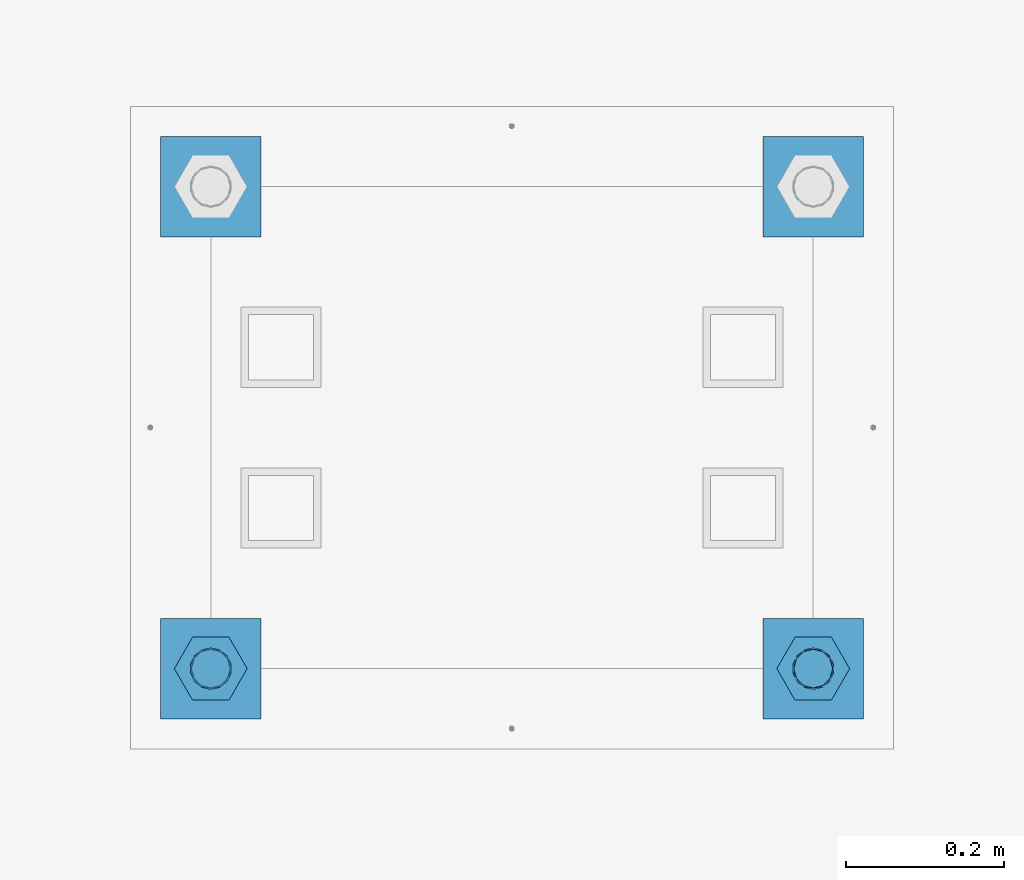
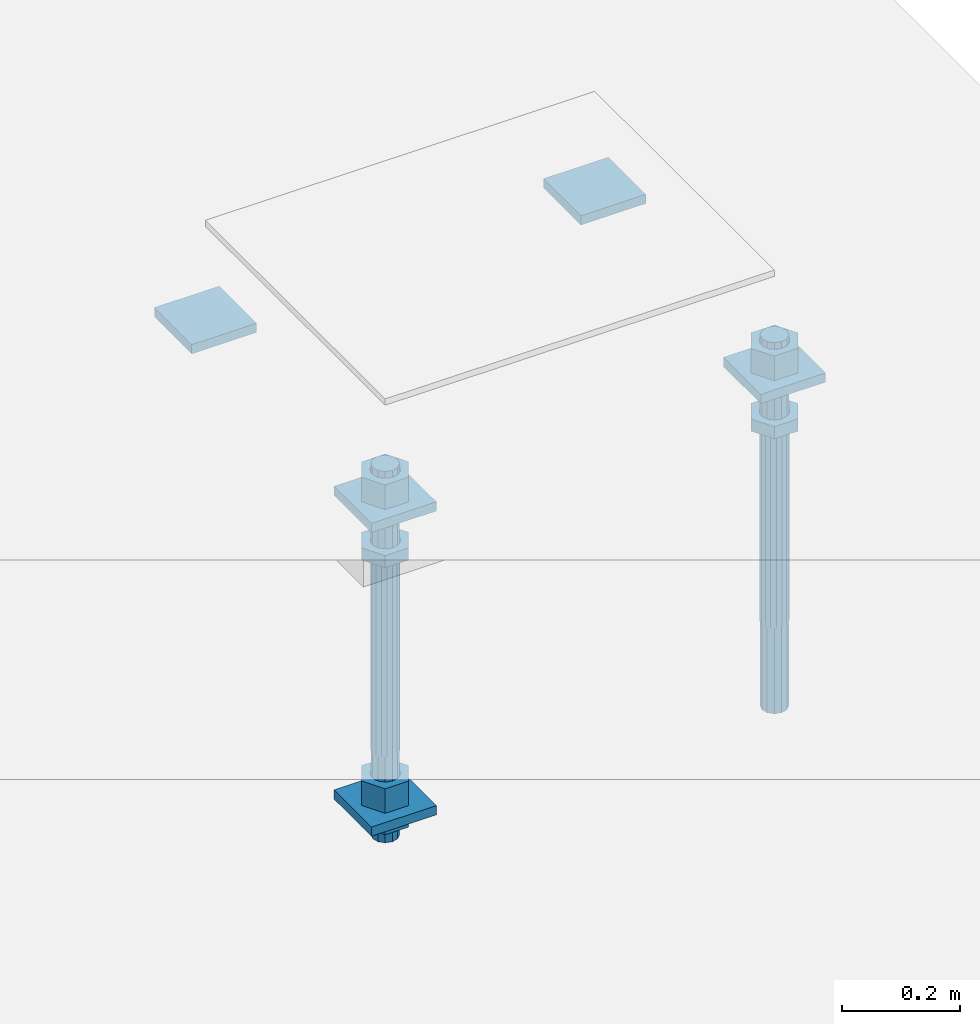
# One storey, part 2678 of 3843: 13 beams, 1 element without a shape of its own.
"""IFC2X3 building model written with IfcOpenShell, lengths in millimetres."""

import ifcopenshell
import ifcopenshell.guid

model = None  # the IFC model being written
_history = None  # IfcOwnerHistory: only IFC2X3 demands one
_inside = {}  # id of a spatial element -> (the spatial element, [elements in it])
_under = {}  # id of a project, library or spatial element -> (it, [spatial elements below it])
_declared = {}  # id of a project -> (the project, [libraries it declares])
_typed = {}  # id of a type object -> (the type object, [elements of that type])
_made_of = {}  # id of a material, layer set ... -> (it, [elements and type objects made of it])


def new_model(schema):
    """Start an empty IFC model of exactly this schema.

    Asked for "IFC4X3", IfcOpenShell would pick the latest addendum, in which some entities
    have other attributes; the version numbers below select the first issue.
    IFC2X3 requires an IfcOwnerHistory on every rooted entity: one is made here for all.
    """
    global model, _history
    if schema == "IFC4X3":
        model = ifcopenshell.file(schema_version=(4, 3, 0, 0))
    else:
        model = ifcopenshell.file(schema=schema)
    _inside.clear()
    _under.clear()
    _declared.clear()
    _typed.clear()
    _made_of.clear()
    _history = None
    if model.schema == "IFC2X3":
        org = make("IfcOrganization", Name="unknown")
        user = make(
            "IfcPersonAndOrganization",
            ThePerson=make("IfcPerson", FamilyName="unknown"),
            TheOrganization=org,
        )
        app = make(
            "IfcApplication",
            ApplicationDeveloper=org,
            Version="unknown",
            ApplicationFullName="unknown",
            ApplicationIdentifier="unknown",
        )
        _history = make(
            "IfcOwnerHistory",
            OwningUser=user,
            OwningApplication=app,
            ChangeAction="ADDED",
            CreationDate=0,
        )
    return model


def make(cls, **values):
    """One entity of the class cls with the attributes given. An attribute that is None is left unset."""
    return model.create_entity(
        cls, **{name: value for name, value in values.items() if value is not None}
    )


def rooted(cls, **values):
    """An entity with a GlobalId (a new one), such as an element, a storey or a relation."""
    return make(cls, GlobalId=ifcopenshell.guid.new(), OwnerHistory=_history, **values)


def si_unit(unit_type, name, prefix=None):
    """IfcSIUnit, for example si_unit("LENGTHUNIT", "METRE", prefix="MILLI")."""
    return make("IfcSIUnit", UnitType=unit_type, Prefix=prefix, Name=name)


def assignment(units):
    """IfcUnitAssignment: the units of a project."""
    return None if units is None else make("IfcUnitAssignment", Units=units)


def point(xyz):
    """IfcCartesianPoint."""
    return None if xyz is None else make("IfcCartesianPoint", Coordinates=xyz)


def direction(xyz):
    """IfcDirection."""
    return None if xyz is None else make("IfcDirection", DirectionRatios=xyz)


def frame(location, z_axis=None, x_axis=None):
    """IfcAxis2Placement3D, a coordinate frame: its origin and axes. An axis left out is left unset."""
    return make(
        "IfcAxis2Placement3D",
        Location=point(location),
        Axis=direction(z_axis),
        RefDirection=direction(x_axis),
    )


def origin_with_axes():
    """The frame at (0, 0, 0) with the z axis (0, 0, 1) and the x axis (1, 0, 0) written out."""
    return frame((0.0, 0.0, 0.0), z_axis=(0.0, 0.0, 1.0), x_axis=(1.0, 0.0, 0.0))


def place(relative_to, where):
    """IfcLocalPlacement: puts the frame where relative to a parent placement (None: the world)."""
    return make(
        "IfcLocalPlacement", PlacementRelTo=relative_to, RelativePlacement=where
    )


def context(
    kind, dimensions, precision=None, world=None, true_north=None, identifier=None
):
    """IfcGeometricRepresentationContext, for example the 3D "Model" context."""
    return make(
        "IfcGeometricRepresentationContext",
        ContextIdentifier=identifier,
        ContextType=kind,
        CoordinateSpaceDimension=dimensions,
        Precision=precision,
        WorldCoordinateSystem=world,
        TrueNorth=true_north,
    )


def subcontext(parent, identifier, kind, view, scale=None):
    """IfcGeometricRepresentationSubContext, for example "Body" below "Model"."""
    return make(
        "IfcGeometricRepresentationSubContext",
        ContextIdentifier=identifier,
        ContextType=kind,
        ParentContext=parent,
        TargetScale=scale,
        TargetView=view,
    )


def project(units=None, contexts=None):
    """IfcProject with its units and contexts."""
    return rooted(
        "IfcProject",
        Name="project",
        RepresentationContexts=contexts,
        UnitsInContext=assignment(units),
    )


def spatial(cls, under=None, at=None, **own):
    """A site, building, storey or space (cls), placed at a placement, below another one or the project."""
    s = rooted(cls, ObjectPlacement=at, **own)
    if under is not None:
        _under.setdefault(under.id(), (under, []))[1].append(s)
    return s


def faces_of(points, faces, orient=None, outer=None):
    """IfcFace entities. A face is a list of loops; a loop is a list of indices into points, from 0.

    orient and outer hold one flag for each loop. By default every Orientation is true, the
    first loop of a face is its IfcFaceOuterBound and the others are IfcFaceBound.
    """
    made = []
    for i, loops in enumerate(faces):
        bounds = []
        for j, loop in enumerate(loops):
            is_outer = j == 0 if outer is None else outer[i][j]
            bounds.append(
                make(
                    "IfcFaceOuterBound" if is_outer else "IfcFaceBound",
                    Bound=make("IfcPolyLoop", Polygon=[points[k] for k in loop]),
                    Orientation=True if orient is None else orient[i][j],
                )
            )
        made.append(make("IfcFace", Bounds=bounds))
    return made


def faceted_brep(points, faces, orient=None, outer=None, voids=None):
    """IfcFacetedBrep: a solid bounded by flat faces; with voids (closed shells), ...WithVoids."""
    shared = [point(p) for p in points]
    hull = make("IfcClosedShell", CfsFaces=faces_of(shared, faces, orient, outer))
    if voids is None:
        return make("IfcFacetedBrep", Outer=hull)
    return make(
        "IfcFacetedBrepWithVoids",
        Outer=hull,
        Voids=[
            make(cls, CfsFaces=faces_of(shared, fs, o, b)) for cls, fs, o, b in voids
        ],
    )


def shape(context_of_items, identifier, shape_type, items):
    """IfcShapeRepresentation: the items that make up one representation, for example the "Body"."""
    return make(
        "IfcShapeRepresentation",
        ContextOfItems=context_of_items,
        RepresentationIdentifier=identifier,
        RepresentationType=shape_type,
        Items=items,
    )


def material(Name=None, Category=None):
    """IfcMaterial."""
    return make("IfcMaterial", Name=Name, Category=Category)


def made_of(thing, what):
    """Note that an element or type object is made of a material, layer set ...; save() writes the relation."""
    if what is not None:
        _made_of.setdefault(what.id(), (what, []))[1].append(thing)
    return thing


def type_object(cls, material=None, **own):
    """A type object (cls), such as IfcWallType, which elements share."""
    return made_of(rooted(cls, **own), material)


def element(
    cls,
    number,
    at=None,
    inside=None,
    cuts=None,
    type_object=None,
    material=None,
    context=None,
    identifier="Body",
    shape_type=None,
    held_by="IfcProductDefinitionShape",
    body=None,
    shapes=None,
    **own,
):
    """One element of the class cls, such as IfcWall. Its Tag is "e" and its number.

    at: its placement. inside: the storey or other place that contains it. cuts: it is an
    opening in that element (IfcRelVoidsElement). A single representation is given by context,
    identifier, shape_type and body (its items); several are given by shapes. held_by: the class
    of the entity that holds the representations. save() writes the other relations.
    """
    e = rooted(cls, Tag="e%d" % number, ObjectPlacement=at, **own)
    if body is not None:
        shapes = [shape(context, identifier, shape_type, body)]
    if shapes is not None:
        e.Representation = make(held_by, Representations=shapes)
    if inside is not None:
        _inside.setdefault(inside.id(), (inside, []))[1].append(e)
    if cuts is not None:
        rooted(
            "IfcRelVoidsElement", RelatingBuildingElement=cuts, RelatedOpeningElement=e
        )
    if type_object is not None:
        _typed.setdefault(type_object.id(), (type_object, []))[1].append(e)
    return made_of(e, material)


def aggregate(whole, parts):
    """IfcRelAggregates: a whole, such as a stair, and the parts it consists of."""
    return rooted("IfcRelAggregates", RelatingObject=whole, RelatedObjects=parts)


def save(model, path):
    """Write the relations noted so far, then the file.

    IfcRelAggregates (storeys below a building ...), IfcRelContainedInSpatialStructure (elements
    in a storey), IfcRelDefinesByType, IfcRelAssociatesMaterial and IfcRelDeclares: one each for
    every whole, place, type object, material and project.
    """
    for whole, parts in _under.values():
        aggregate(whole, parts)
    for where, things in _inside.values():
        rooted(
            "IfcRelContainedInSpatialStructure",
            RelatedElements=things,
            RelatingStructure=where,
        )
    for kind, things in _typed.values():
        rooted("IfcRelDefinesByType", RelatedObjects=things, RelatingType=kind)
    for what, things in _made_of.values():
        rooted("IfcRelAssociatesMaterial", RelatedObjects=things, RelatingMaterial=what)
    for by, libraries in _declared.values():
        rooted("IfcRelDeclares", RelatingContext=by, RelatedDefinitions=libraries)
    model.write(path)


model = new_model("IFC2X3")

# Units and contexts
model_context = context("Model", 3, precision=1e-05, world=origin_with_axes())
body_context = subcontext(model_context, "Body", "Model", "MODEL_VIEW")
ifc_project = project(units=[si_unit("LENGTHUNIT", "METRE", prefix="MILLI"), si_unit("AREAUNIT", "SQUARE_METRE"), si_unit("VOLUMEUNIT", "CUBIC_METRE"), si_unit("MASSUNIT", "GRAM", prefix="KILO"), si_unit("TIMEUNIT", "SECOND"), si_unit("PLANEANGLEUNIT", "RADIAN"), si_unit("SOLIDANGLEUNIT", "STERADIAN"), si_unit("THERMODYNAMICTEMPERATUREUNIT", "DEGREE_CELSIUS"), si_unit("LUMINOUSINTENSITYUNIT", "LUMEN")], contexts=[model_context])

# Site, building, storey
site_placement = place(None, origin_with_axes())
site = spatial("IfcSite", under=ifc_project, at=site_placement, CompositionType="ELEMENT")
building_placement = place(site_placement, origin_with_axes())
building = spatial("IfcBuilding", under=site, at=building_placement, Name="Undefined", CompositionType="ELEMENT")
storey_placement = place(building_placement, origin_with_axes())
storey = spatial("IfcBuildingStorey", under=building, at=storey_placement, Name="Undefined", CompositionType="ELEMENT", Elevation=0.0)

# Assembly, beams
assembly_placement = place(storey_placement, origin_with_axes())
assembly = element("IfcElementAssembly", 1, at=assembly_placement, inside=storey, Name="TEMPLATE", AssemblyPlace="NOTDEFINED", PredefinedType="RIGID_FRAME")
ifc_material_1 = material(Name="STEEL/A572-50")
beam_type_1 = type_object("IfcBeamType", PredefinedType="NOTDEFINED")
beam_1_placement = place(assembly_placement, frame((118465.6, 24765.0000015259, 29873.575), z_axis=(1.0, 0.0, 0.0), x_axis=(0.0, 1.0, 0.0)))
beam_1 = element("IfcBeam", 2, at=beam_1_placement, type_object=beam_type_1, material=ifc_material_1, Name="WASHER_PLATE", context=body_context, shape_type="Brep", body=[
    faceted_brep([(0.0, 9.52500000000146, -63.5), (0.0, 9.52500000000146, 63.5), (127.0, 9.52500000000146, 63.5), (127.0, 9.52500000000146, -63.5), (0.0, -9.52500000000146, 63.5), (127.0, -9.52500000000146, 63.5), (0.0, -9.52500000000146, -63.5), (127.0, -9.52500000000146, -63.5)], [[[0, 1, 2, 3]], [[1, 4, 5, 2]], [[4, 6, 7, 5]], [[6, 0, 3, 7]], [[5, 7, 3, 2]], [[6, 4, 1, 0]]]),
])
beam_2_placement = place(assembly_placement, frame((119227.6, 24765.0000015259, 29873.575), z_axis=(1.0, 0.0, 0.0), x_axis=(0.0, 1.0, 0.0)))
beam_2 = element("IfcBeam", 3, at=beam_2_placement, type_object=beam_type_1, material=ifc_material_1, Name="WASHER_PLATE", context=body_context, shape_type="Brep", body=[
    faceted_brep([(0.0, 9.52500000000146, -63.5), (0.0, 9.52500000000146, 63.5), (127.0, 9.52500000000146, 63.5), (127.0, 9.52500000000146, -63.5), (0.0, -9.52500000000146, 63.5), (127.0, -9.52500000000146, 63.5), (0.0, -9.52500000000146, -63.5), (127.0, -9.52500000000146, -63.5)], [[[0, 1, 2, 3]], [[1, 4, 5, 2]], [[4, 6, 7, 5]], [[6, 0, 3, 7]], [[5, 7, 3, 2]], [[6, 4, 1, 0]]]),
])
beam_3_placement = place(assembly_placement, frame((118465.6, 25374.6000015259, 29873.575), z_axis=(1.0, 0.0, 0.0), x_axis=(0.0, 1.0, 0.0)))
beam_3 = element("IfcBeam", 4, at=beam_3_placement, type_object=beam_type_1, material=ifc_material_1, Name="WASHER_PLATE", context=body_context, shape_type="Brep", body=[
    faceted_brep([(0.0, 9.52500000000146, -63.5), (0.0, 9.52500000000146, 63.5), (127.0, 9.52500000000146, 63.5), (127.0, 9.52500000000146, -63.5), (0.0, -9.52500000000146, 63.5), (127.0, -9.52500000000146, 63.5), (0.0, -9.52500000000146, -63.5), (127.0, -9.52500000000146, -63.5)], [[[0, 1, 2, 3]], [[1, 4, 5, 2]], [[4, 6, 7, 5]], [[6, 0, 3, 7]], [[5, 7, 3, 2]], [[6, 4, 1, 0]]]),
])
beam_4_placement = place(assembly_placement, frame((119227.6, 25374.6000015259, 29873.575), z_axis=(1.0, 0.0, 0.0), x_axis=(0.0, 1.0, 0.0)))
beam_4 = element("IfcBeam", 5, at=beam_4_placement, type_object=beam_type_1, material=ifc_material_1, Name="WASHER_PLATE", context=body_context, shape_type="Brep", body=[
    faceted_brep([(0.0, 9.52500000000146, -63.5), (0.0, 9.52500000000146, 63.5), (127.0, 9.52500000000146, 63.5), (127.0, 9.52500000000146, -63.5), (0.0, -9.52500000000146, 63.5), (127.0, -9.52500000000146, 63.5), (0.0, -9.52500000000146, -63.5), (127.0, -9.52500000000146, -63.5)], [[[0, 1, 2, 3]], [[1, 4, 5, 2]], [[4, 6, 7, 5]], [[6, 0, 3, 7]], [[5, 7, 3, 2]], [[6, 4, 1, 0]]]),
])
beam_5_placement = place(assembly_placement, frame((118465.6, 24765.0000015259, 29244.925), z_axis=(1.0, 0.0, 0.0), x_axis=(0.0, 1.0, 0.0)))
beam_5 = element("IfcBeam", 6, at=beam_5_placement, type_object=beam_type_1, material=ifc_material_1, Name="WASHER_PLATE", context=body_context, shape_type="Brep", body=[
    faceted_brep([(0.0, 9.52500000000146, -63.5), (0.0, 9.52500000000146, 63.5), (127.0, 9.52500000000146, 63.5), (127.0, 9.52500000000146, -63.5), (0.0, -9.52500000000146, 63.5), (127.0, -9.52500000000146, 63.5), (0.0, -9.52500000000146, -63.5), (127.0, -9.52500000000146, -63.5)], [[[0, 1, 2, 3]], [[1, 4, 5, 2]], [[4, 6, 7, 5]], [[6, 0, 3, 7]], [[5, 7, 3, 2]], [[6, 4, 1, 0]]]),
])
ifc_material_2 = material(Name="STEEL/A36")
beam_type_2 = type_object("IfcBeamType", Name="2_HALF_NUT", PredefinedType="NOTDEFINED")
beam_6_placement = place(assembly_placement, frame((118465.6, 24828.5000015259, 29787.85), z_axis=(0.0, 1.0, 0.0), x_axis=(0.0, 0.0, -1.0)))
beam_6 = element("IfcBeam", 7, at=beam_6_placement, type_object=beam_type_2, material=ifc_material_2, Name="NUT", ObjectType="2_HALF_NUT", context=body_context, shape_type="Brep", body=[
    faceted_brep([(0.0, -46.0369987487793, 0.0), (0.0, -23.0184993743896, -39.869213104248), (25.4000000000015, -23.0184993743896, -39.869213104248), (25.4000000000015, -46.0369987487793, 0.0), (0.0, 23.0184993743896, -39.869213104248), (25.4000000000015, 23.0184993743896, -39.869213104248), (0.0, 46.0369987487793, 0.0), (25.4000000000015, 46.0369987487793, 0.0), (0.0, 23.0184993743896, 39.869213104248), (25.4000000000015, 23.0184993743896, 39.869213104248), (0.0, -23.0184993743896, 39.869213104248), (25.4000000000015, -23.0184993743896, 39.869213104248), (0.0, 0.0, 26.1940002441406), (0.0, 11.3650617044477, 23.5999013092805), (25.4000000000015, 11.3650617044477, 23.5999013092805), (25.4000000000015, 0.0, 26.1940002441406), (0.0, 20.4791109456419, 16.3316083006721), (25.4000000000015, 20.4791109456419, 16.3316083006721), (0.0, 25.5370200498292, 5.82867859874386), (25.4000000000015, 25.5370200498292, 5.82867859874386), (0.0, 25.5370200498292, -5.82867859874386), (25.4000000000015, 25.5370200498292, -5.82867859874386), (0.0, 20.4791109456419, -16.3316083006721), (25.4000000000015, 20.4791109456419, -16.3316083006721), (0.0, 11.3650617044477, -23.5999013092805), (25.4000000000015, 11.3650617044477, -23.5999013092805), (0.0, 0.0, -26.1940002441406), (25.4000000000015, 0.0, -26.1940002441406), (0.0, -11.3650617044477, -23.5999013092805), (25.4000000000015, -11.3650617044477, -23.5999013092805), (0.0, -20.4791109456419, -16.3316083006721), (25.4000000000015, -20.4791109456419, -16.3316083006721), (0.0, -25.5370200498292, -5.82867859874386), (25.4000000000015, -25.5370200498292, -5.82867859874386), (0.0, -25.5370200498292, 5.82867859874386), (25.4000000000015, -25.5370200498292, 5.82867859874386), (0.0, -20.4791109456419, 16.3316083006721), (25.4000000000015, -20.4791109456419, 16.3316083006721), (0.0, -11.3650617044477, 23.5999013092805), (25.4000000000015, -11.3650617044477, 23.5999013092805)], [[[0, 1, 2, 3]], [[1, 4, 5, 2]], [[4, 6, 7, 5]], [[6, 8, 9, 7]], [[8, 10, 11, 9]], [[10, 0, 3, 11]], [[12, 13, 14, 15]], [[13, 16, 17, 14]], [[16, 18, 19, 17]], [[18, 20, 21, 19]], [[20, 22, 23, 21]], [[22, 24, 25, 23]], [[24, 26, 27, 25]], [[26, 28, 29, 27]], [[28, 30, 31, 29]], [[30, 32, 33, 31]], [[32, 34, 35, 33]], [[34, 36, 37, 35]], [[36, 38, 39, 37]], [[38, 12, 15, 39]], [[5, 7, 9, 11, 3, 2], [17, 19, 21, 23, 25, 27, 29, 31, 33, 35, 37, 39, 15, 14]], [[10, 8, 6, 4, 1, 0], [38, 36, 34, 32, 30, 28, 26, 24, 22, 20, 18, 16, 13, 12]]]),
])
beam_7_placement = place(assembly_placement, frame((118465.6, 24828.5000015259, 29235.4), z_axis=(0.0, 1.0, 0.0), x_axis=(0.0, 0.0, -1.0)))
beam_7 = element("IfcBeam", 8, at=beam_7_placement, type_object=beam_type_2, material=ifc_material_2, Name="NUT", ObjectType="2_HALF_NUT", context=body_context, shape_type="Brep", body=[
    faceted_brep([(0.0, -46.0369987487793, 0.0), (0.0, -23.0184993743896, -39.869213104248), (25.4000000000015, -23.0184993743896, -39.869213104248), (25.4000000000015, -46.0369987487793, 0.0), (0.0, 23.0184993743896, -39.869213104248), (25.4000000000015, 23.0184993743896, -39.869213104248), (0.0, 46.0369987487793, 0.0), (25.4000000000015, 46.0369987487793, 0.0), (0.0, 23.0184993743896, 39.869213104248), (25.4000000000015, 23.0184993743896, 39.869213104248), (0.0, -23.0184993743896, 39.869213104248), (25.4000000000015, -23.0184993743896, 39.869213104248), (0.0, 0.0, 26.1940002441406), (0.0, 11.3650617044477, 23.5999013092805), (25.4000000000015, 11.3650617044477, 23.5999013092805), (25.4000000000015, 0.0, 26.1940002441406), (0.0, 20.4791109456419, 16.3316083006721), (25.4000000000015, 20.4791109456419, 16.3316083006721), (0.0, 25.5370200498292, 5.82867859874386), (25.4000000000015, 25.5370200498292, 5.82867859874386), (0.0, 25.5370200498292, -5.82867859874386), (25.4000000000015, 25.5370200498292, -5.82867859874386), (0.0, 20.4791109456419, -16.3316083006721), (25.4000000000015, 20.4791109456419, -16.3316083006721), (0.0, 11.3650617044477, -23.5999013092805), (25.4000000000015, 11.3650617044477, -23.5999013092805), (0.0, 0.0, -26.1940002441406), (25.4000000000015, 0.0, -26.1940002441406), (0.0, -11.3650617044477, -23.5999013092805), (25.4000000000015, -11.3650617044477, -23.5999013092805), (0.0, -20.4791109456419, -16.3316083006721), (25.4000000000015, -20.4791109456419, -16.3316083006721), (0.0, -25.5370200498292, -5.82867859874386), (25.4000000000015, -25.5370200498292, -5.82867859874386), (0.0, -25.5370200498292, 5.82867859874386), (25.4000000000015, -25.5370200498292, 5.82867859874386), (0.0, -20.4791109456419, 16.3316083006721), (25.4000000000015, -20.4791109456419, 16.3316083006721), (0.0, -11.3650617044477, 23.5999013092805), (25.4000000000015, -11.3650617044477, 23.5999013092805)], [[[0, 1, 2, 3]], [[1, 4, 5, 2]], [[4, 6, 7, 5]], [[6, 8, 9, 7]], [[8, 10, 11, 9]], [[10, 0, 3, 11]], [[12, 13, 14, 15]], [[13, 16, 17, 14]], [[16, 18, 19, 17]], [[18, 20, 21, 19]], [[20, 22, 23, 21]], [[22, 24, 25, 23]], [[24, 26, 27, 25]], [[26, 28, 29, 27]], [[28, 30, 31, 29]], [[30, 32, 33, 31]], [[32, 34, 35, 33]], [[34, 36, 37, 35]], [[36, 38, 39, 37]], [[38, 12, 15, 39]], [[5, 7, 9, 11, 3, 2], [17, 19, 21, 23, 25, 27, 29, 31, 33, 35, 37, 39, 15, 14]], [[10, 8, 6, 4, 1, 0], [38, 36, 34, 32, 30, 28, 26, 24, 22, 20, 18, 16, 13, 12]]]),
])
beam_8_placement = place(assembly_placement, frame((119227.6, 24828.5000015259, 29787.85), z_axis=(0.0, 1.0, 0.0), x_axis=(0.0, 0.0, -1.0)))
beam_8 = element("IfcBeam", 9, at=beam_8_placement, type_object=beam_type_2, material=ifc_material_2, Name="NUT", ObjectType="2_HALF_NUT", context=body_context, shape_type="Brep", body=[
    faceted_brep([(0.0, -46.0369987487793, 0.0), (0.0, -23.0184993743896, -39.869213104248), (25.4000000000015, -23.0184993743896, -39.869213104248), (25.4000000000015, -46.0369987487793, 0.0), (0.0, 23.0184993743896, -39.869213104248), (25.4000000000015, 23.0184993743896, -39.869213104248), (0.0, 46.0369987487793, 0.0), (25.4000000000015, 46.0369987487793, 0.0), (0.0, 23.0184993743896, 39.869213104248), (25.4000000000015, 23.0184993743896, 39.869213104248), (0.0, -23.0184993743896, 39.869213104248), (25.4000000000015, -23.0184993743896, 39.869213104248), (0.0, 0.0, 26.1940002441406), (0.0, 11.3650617044477, 23.5999013092805), (25.4000000000015, 11.3650617044477, 23.5999013092805), (25.4000000000015, 0.0, 26.1940002441406), (0.0, 20.4791109456419, 16.3316083006721), (25.4000000000015, 20.4791109456419, 16.3316083006721), (0.0, 25.5370200498292, 5.82867859874386), (25.4000000000015, 25.5370200498292, 5.82867859874386), (0.0, 25.5370200498292, -5.82867859874386), (25.4000000000015, 25.5370200498292, -5.82867859874386), (0.0, 20.4791109456419, -16.3316083006721), (25.4000000000015, 20.4791109456419, -16.3316083006721), (0.0, 11.3650617044477, -23.5999013092805), (25.4000000000015, 11.3650617044477, -23.5999013092805), (0.0, 0.0, -26.1940002441406), (25.4000000000015, 0.0, -26.1940002441406), (0.0, -11.3650617044477, -23.5999013092805), (25.4000000000015, -11.3650617044477, -23.5999013092805), (0.0, -20.4791109456419, -16.3316083006721), (25.4000000000015, -20.4791109456419, -16.3316083006721), (0.0, -25.5370200498292, -5.82867859874386), (25.4000000000015, -25.5370200498292, -5.82867859874386), (0.0, -25.5370200498292, 5.82867859874386), (25.4000000000015, -25.5370200498292, 5.82867859874386), (0.0, -20.4791109456419, 16.3316083006721), (25.4000000000015, -20.4791109456419, 16.3316083006721), (0.0, -11.3650617044477, 23.5999013092805), (25.4000000000015, -11.3650617044477, 23.5999013092805)], [[[0, 1, 2, 3]], [[1, 4, 5, 2]], [[4, 6, 7, 5]], [[6, 8, 9, 7]], [[8, 10, 11, 9]], [[10, 0, 3, 11]], [[12, 13, 14, 15]], [[13, 16, 17, 14]], [[16, 18, 19, 17]], [[18, 20, 21, 19]], [[20, 22, 23, 21]], [[22, 24, 25, 23]], [[24, 26, 27, 25]], [[26, 28, 29, 27]], [[28, 30, 31, 29]], [[30, 32, 33, 31]], [[32, 34, 35, 33]], [[34, 36, 37, 35]], [[36, 38, 39, 37]], [[38, 12, 15, 39]], [[5, 7, 9, 11, 3, 2], [17, 19, 21, 23, 25, 27, 29, 31, 33, 35, 37, 39, 15, 14]], [[10, 8, 6, 4, 1, 0], [38, 36, 34, 32, 30, 28, 26, 24, 22, 20, 18, 16, 13, 12]]]),
])
beam_type_3 = type_object("IfcBeamType", Name="2_HEAVY_HEX_NUT", PredefinedType="NOTDEFINED")
beam_9_placement = place(assembly_placement, frame((118465.6, 24828.5000015259, 29933.9), z_axis=(0.0, 1.0, 0.0), x_axis=(0.0, 0.0, -1.0)))
beam_9 = element("IfcBeam", 10, at=beam_9_placement, type_object=beam_type_3, material=ifc_material_2, Name="NUT", ObjectType="2_HEAVY_HEX_NUT", context=body_context, shape_type="Brep", body=[
    faceted_brep([(0.0, -46.0369987487793, 0.0), (0.0, -23.0184993743896, -39.869213104248), (50.7999999999993, -23.0184993743896, -39.869213104248), (50.7999999999993, -46.0369987487793, 0.0), (0.0, 23.0184993743896, -39.869213104248), (50.7999999999993, 23.0184993743896, -39.869213104248), (0.0, 46.0369987487793, 0.0), (50.7999999999993, 46.0369987487793, 0.0), (0.0, 23.0184993743896, 39.869213104248), (50.7999999999993, 23.0184993743896, 39.869213104248), (0.0, -23.0184993743896, 39.869213104248), (50.7999999999993, -23.0184993743896, 39.869213104248), (0.0, 0.0, 26.1940002441406), (0.0, 11.3650617044477, 23.5999013092805), (50.7999999999993, 11.3650617044477, 23.5999013092805), (50.7999999999993, 0.0, 26.1940002441406), (0.0, 20.4791109456419, 16.3316083006721), (50.7999999999993, 20.4791109456419, 16.3316083006721), (0.0, 25.5370200498292, 5.82867859874386), (50.7999999999993, 25.5370200498292, 5.82867859874386), (0.0, 25.5370200498292, -5.82867859874386), (50.7999999999993, 25.5370200498292, -5.82867859874386), (0.0, 20.4791109456419, -16.3316083006721), (50.7999999999993, 20.4791109456419, -16.3316083006721), (0.0, 11.3650617044477, -23.5999013092805), (50.7999999999993, 11.3650617044477, -23.5999013092805), (0.0, 0.0, -26.1940002441406), (50.7999999999993, 0.0, -26.1940002441406), (0.0, -11.3650617044477, -23.5999013092805), (50.7999999999993, -11.3650617044477, -23.5999013092805), (0.0, -20.4791109456419, -16.3316083006721), (50.7999999999993, -20.4791109456419, -16.3316083006721), (0.0, -25.5370200498292, -5.82867859874386), (50.7999999999993, -25.5370200498292, -5.82867859874386), (0.0, -25.5370200498292, 5.82867859874386), (50.7999999999993, -25.5370200498292, 5.82867859874386), (0.0, -20.4791109456419, 16.3316083006721), (50.7999999999993, -20.4791109456419, 16.3316083006721), (0.0, -11.3650617044477, 23.5999013092805), (50.7999999999993, -11.3650617044477, 23.5999013092805)], [[[0, 1, 2, 3]], [[1, 4, 5, 2]], [[4, 6, 7, 5]], [[6, 8, 9, 7]], [[8, 10, 11, 9]], [[10, 0, 3, 11]], [[12, 13, 14, 15]], [[13, 16, 17, 14]], [[16, 18, 19, 17]], [[18, 20, 21, 19]], [[20, 22, 23, 21]], [[22, 24, 25, 23]], [[24, 26, 27, 25]], [[26, 28, 29, 27]], [[28, 30, 31, 29]], [[30, 32, 33, 31]], [[32, 34, 35, 33]], [[34, 36, 37, 35]], [[36, 38, 39, 37]], [[38, 12, 15, 39]], [[5, 7, 9, 11, 3, 2], [17, 19, 21, 23, 25, 27, 29, 31, 33, 35, 37, 39, 15, 14]], [[10, 8, 6, 4, 1, 0], [38, 36, 34, 32, 30, 28, 26, 24, 22, 20, 18, 16, 13, 12]]]),
])
beam_10_placement = place(assembly_placement, frame((118465.6, 24828.5000015259, 29305.25), z_axis=(0.0, 1.0, 0.0), x_axis=(0.0, 0.0, -1.0)))
beam_10 = element("IfcBeam", 11, at=beam_10_placement, type_object=beam_type_3, material=ifc_material_2, Name="NUT", ObjectType="2_HEAVY_HEX_NUT", context=body_context, shape_type="Brep", body=[
    faceted_brep([(0.0, -46.0369987487793, 0.0), (0.0, -23.0184993743896, -39.869213104248), (50.7999999999993, -23.0184993743896, -39.869213104248), (50.7999999999993, -46.0369987487793, 0.0), (0.0, 23.0184993743896, -39.869213104248), (50.7999999999993, 23.0184993743896, -39.869213104248), (0.0, 46.0369987487793, 0.0), (50.7999999999993, 46.0369987487793, 0.0), (0.0, 23.0184993743896, 39.869213104248), (50.7999999999993, 23.0184993743896, 39.869213104248), (0.0, -23.0184993743896, 39.869213104248), (50.7999999999993, -23.0184993743896, 39.869213104248), (0.0, 0.0, 26.1940002441406), (0.0, 11.3650617044477, 23.5999013092805), (50.7999999999993, 11.3650617044477, 23.5999013092805), (50.7999999999993, 0.0, 26.1940002441406), (0.0, 20.4791109456419, 16.3316083006721), (50.7999999999993, 20.4791109456419, 16.3316083006721), (0.0, 25.5370200498292, 5.82867859874386), (50.7999999999993, 25.5370200498292, 5.82867859874386), (0.0, 25.5370200498292, -5.82867859874386), (50.7999999999993, 25.5370200498292, -5.82867859874386), (0.0, 20.4791109456419, -16.3316083006721), (50.7999999999993, 20.4791109456419, -16.3316083006721), (0.0, 11.3650617044477, -23.5999013092805), (50.7999999999993, 11.3650617044477, -23.5999013092805), (0.0, 0.0, -26.1940002441406), (50.7999999999993, 0.0, -26.1940002441406), (0.0, -11.3650617044477, -23.5999013092805), (50.7999999999993, -11.3650617044477, -23.5999013092805), (0.0, -20.4791109456419, -16.3316083006721), (50.7999999999993, -20.4791109456419, -16.3316083006721), (0.0, -25.5370200498292, -5.82867859874386), (50.7999999999993, -25.5370200498292, -5.82867859874386), (0.0, -25.5370200498292, 5.82867859874386), (50.7999999999993, -25.5370200498292, 5.82867859874386), (0.0, -20.4791109456419, 16.3316083006721), (50.7999999999993, -20.4791109456419, 16.3316083006721), (0.0, -11.3650617044477, 23.5999013092805), (50.7999999999993, -11.3650617044477, 23.5999013092805)], [[[0, 1, 2, 3]], [[1, 4, 5, 2]], [[4, 6, 7, 5]], [[6, 8, 9, 7]], [[8, 10, 11, 9]], [[10, 0, 3, 11]], [[12, 13, 14, 15]], [[13, 16, 17, 14]], [[16, 18, 19, 17]], [[18, 20, 21, 19]], [[20, 22, 23, 21]], [[22, 24, 25, 23]], [[24, 26, 27, 25]], [[26, 28, 29, 27]], [[28, 30, 31, 29]], [[30, 32, 33, 31]], [[32, 34, 35, 33]], [[34, 36, 37, 35]], [[36, 38, 39, 37]], [[38, 12, 15, 39]], [[5, 7, 9, 11, 3, 2], [17, 19, 21, 23, 25, 27, 29, 31, 33, 35, 37, 39, 15, 14]], [[10, 8, 6, 4, 1, 0], [38, 36, 34, 32, 30, 28, 26, 24, 22, 20, 18, 16, 13, 12]]]),
])
beam_11_placement = place(assembly_placement, frame((119227.6, 24828.5000015259, 29933.9), z_axis=(0.0, 1.0, 0.0), x_axis=(0.0, 0.0, -1.0)))
beam_11 = element("IfcBeam", 12, at=beam_11_placement, type_object=beam_type_3, material=ifc_material_2, Name="NUT", ObjectType="2_HEAVY_HEX_NUT", context=body_context, shape_type="Brep", body=[
    faceted_brep([(0.0, -46.0369987487793, 0.0), (0.0, -23.0184993743896, -39.869213104248), (50.7999999999993, -23.0184993743896, -39.869213104248), (50.7999999999993, -46.0369987487793, 0.0), (0.0, 23.0184993743896, -39.869213104248), (50.7999999999993, 23.0184993743896, -39.869213104248), (0.0, 46.0369987487793, 0.0), (50.7999999999993, 46.0369987487793, 0.0), (0.0, 23.0184993743896, 39.869213104248), (50.7999999999993, 23.0184993743896, 39.869213104248), (0.0, -23.0184993743896, 39.869213104248), (50.7999999999993, -23.0184993743896, 39.869213104248), (0.0, 0.0, 26.1940002441406), (0.0, 11.3650617044477, 23.5999013092805), (50.7999999999993, 11.3650617044477, 23.5999013092805), (50.7999999999993, 0.0, 26.1940002441406), (0.0, 20.4791109456419, 16.3316083006721), (50.7999999999993, 20.4791109456419, 16.3316083006721), (0.0, 25.5370200498292, 5.82867859874386), (50.7999999999993, 25.5370200498292, 5.82867859874386), (0.0, 25.5370200498292, -5.82867859874386), (50.7999999999993, 25.5370200498292, -5.82867859874386), (0.0, 20.4791109456419, -16.3316083006721), (50.7999999999993, 20.4791109456419, -16.3316083006721), (0.0, 11.3650617044477, -23.5999013092805), (50.7999999999993, 11.3650617044477, -23.5999013092805), (0.0, 0.0, -26.1940002441406), (50.7999999999993, 0.0, -26.1940002441406), (0.0, -11.3650617044477, -23.5999013092805), (50.7999999999993, -11.3650617044477, -23.5999013092805), (0.0, -20.4791109456419, -16.3316083006721), (50.7999999999993, -20.4791109456419, -16.3316083006721), (0.0, -25.5370200498292, -5.82867859874386), (50.7999999999993, -25.5370200498292, -5.82867859874386), (0.0, -25.5370200498292, 5.82867859874386), (50.7999999999993, -25.5370200498292, 5.82867859874386), (0.0, -20.4791109456419, 16.3316083006721), (50.7999999999993, -20.4791109456419, 16.3316083006721), (0.0, -11.3650617044477, 23.5999013092805), (50.7999999999993, -11.3650617044477, 23.5999013092805)], [[[0, 1, 2, 3]], [[1, 4, 5, 2]], [[4, 6, 7, 5]], [[6, 8, 9, 7]], [[8, 10, 11, 9]], [[10, 0, 3, 11]], [[12, 13, 14, 15]], [[13, 16, 17, 14]], [[16, 18, 19, 17]], [[18, 20, 21, 19]], [[20, 22, 23, 21]], [[22, 24, 25, 23]], [[24, 26, 27, 25]], [[26, 28, 29, 27]], [[28, 30, 31, 29]], [[30, 32, 33, 31]], [[32, 34, 35, 33]], [[34, 36, 37, 35]], [[36, 38, 39, 37]], [[38, 12, 15, 39]], [[5, 7, 9, 11, 3, 2], [17, 19, 21, 23, 25, 27, 29, 31, 33, 35, 37, 39, 15, 14]], [[10, 8, 6, 4, 1, 0], [38, 36, 34, 32, 30, 28, 26, 24, 22, 20, 18, 16, 13, 12]]]),
])
ifc_material_3 = material()
beam_type_4 = type_object("IfcBeamType", PredefinedType="NOTDEFINED")
beam_12_placement = place(assembly_placement, frame((118465.600001526, 24828.5, 29762.45), z_axis=(1.0, 0.0, 0.0), x_axis=(0.0, 0.0, -1.0)))
beam_12 = element("IfcBeam", 13, at=beam_12_placement, type_object=beam_type_4, material=ifc_material_3, Name="ANCHOR_ROD", context=body_context, shape_type="Brep", body=[
    faceted_brep([(0.0, -23.4665401257807, -9.72015918207035), (0.0, -17.9605122421344, -17.9605122421417), (406.399999999998, -17.9605122421344, -17.9605122421417), (406.399999999998, -23.4665401257807, -9.72015918207035), (0.0, -9.72015918207762, -23.466540125788), (406.399999999998, -9.72015918207762, -23.466540125788), (0.0, 0.0, -25.4000000000015), (406.399999999998, 0.0, -25.4000000000015), (0.0, 9.72015918207762, -23.466540125788), (406.399999999998, 9.72015918207762, -23.466540125788), (0.0, 17.9605122421344, -17.9605122421417), (406.399999999998, 17.9605122421344, -17.9605122421417), (0.0, 23.4665401257807, -9.72015918207035), (406.399999999998, 23.4665401257807, -9.72015918207035), (0.0, 25.3999996185303, 0.0), (406.399999999998, 25.3999999999942, 0.0), (0.0, 23.4665401257807, 9.72015918207035), (406.399999999998, 23.4665401257807, 9.72015918207035), (0.0, 17.9605122421344, 17.9605122421417), (406.399999999998, 17.9605122421344, 17.9605122421417), (0.0, 9.72015918207762, 23.466540125788), (406.399999999998, 9.72015918207762, 23.466540125788), (0.0, 0.0, 25.4000000000015), (406.399999999998, 0.0, 25.4000000000015), (0.0, -9.72015918207762, 23.466540125788), (406.399999999998, -9.72015918207762, 23.466540125788), (0.0, -17.9605122421344, 17.9605122421417), (406.399999999998, -17.9605122421344, 17.9605122421417), (0.0, -23.4665401257807, 9.72015918207035), (406.399999999998, -23.4665401257807, 9.72015918207035), (0.0, -25.3999996185303, 0.0), (406.399999999998, -25.3999999999942, 0.0), (584.200000000001, -12.2499999999854, -21.2176223927163), (584.200000000001, 1.45519152283669e-11, -24.5), (584.200000000001, 12.2500000000146, -21.2176223927163), (584.200000000001, 21.2176223927381, -12.25), (584.200000000001, 24.5000000000146, 0.0), (584.200000000001, 21.2176223927381, 12.25), (584.200000000001, 12.2500000000146, 21.2176223927163), (584.200000000001, 1.45519152283669e-11, 24.5), (584.200000000001, -12.2499999999854, 21.2176223927163), (584.200000000001, -21.217622392709, 12.25), (584.200000000001, -24.4999999999854, 0.0), (584.200000000001, -21.217622392709, -12.25), (406.399999999998, -24.4999999999854, 0.0), (406.399999999998, -21.217622392709, -12.25), (406.399999999998, -12.2499999999854, -21.2176223927163), (406.399999999998, 1.45519152283669e-11, -24.5), (406.399999999998, 12.2500000000146, -21.2176223927163), (406.399999999998, 21.2176223927381, -12.25), (406.399999999998, 24.5000000000146, 0.0), (406.399999999998, 21.2176223927381, 12.25), (406.399999999998, 12.2500000000146, 21.2176223927163), (406.399999999998, 1.45519152283669e-11, 24.5), (406.399999999998, -12.2499999999854, 21.2176223927163), (406.399999999998, -21.217622392709, 12.25), (0.0, 12.2500000000146, 21.2176223927163), (0.0, 1.45519152283669e-11, 24.5), (0.0, -12.2499999999854, 21.2176223927163), (0.0, -21.217622392709, 12.25), (0.0, -24.4999999999854, 0.0), (0.0, -21.217622392709, -12.25), (0.0, -12.2499999999854, -21.2176223927163), (0.0, 1.45519152283669e-11, -24.5), (0.0, 12.2500000000146, -21.2176223927163), (0.0, 21.2176223927381, -12.25), (0.0, 24.5000000000146, 0.0), (0.0, 21.2176223927381, 12.25), (-184.150000000001, -21.217622392709, 12.25), (-184.150000000001, -12.2499999999854, 21.2176223927163), (-184.150000000001, 1.45519152283669e-11, 24.5), (-184.150000000001, 12.2500000000146, 21.2176223927163), (-184.150000000001, 21.2176223927381, 12.25), (-184.150000000001, 24.5000000000146, 0.0), (-184.150000000001, 21.2176223927381, -12.25), (-184.150000000001, 12.2500000000146, -21.2176223927163), (-184.150000000001, 1.45519152283669e-11, -24.5), (-184.150000000001, -12.2499999999854, -21.2176223927163), (-184.150000000001, -21.217622392709, -12.25), (-184.150000000001, -24.4999999999854, 0.0)], [[[0, 1, 2, 3]], [[1, 4, 5, 2]], [[4, 6, 7, 5]], [[6, 8, 9, 7]], [[8, 10, 11, 9]], [[10, 12, 13, 11]], [[12, 14, 15, 13]], [[14, 16, 17, 15]], [[16, 18, 19, 17]], [[18, 20, 21, 19]], [[20, 22, 23, 21]], [[22, 24, 25, 23]], [[24, 26, 27, 25]], [[26, 28, 29, 27]], [[28, 30, 31, 29]], [[32, 33, 34, 35, 36, 37, 38, 39, 40, 41, 42, 43]], [[43, 42, 44, 45]], [[32, 43, 45, 46]], [[33, 32, 46, 47]], [[34, 33, 47, 48]], [[35, 34, 48, 49]], [[36, 35, 49, 50]], [[37, 36, 50, 51]], [[38, 37, 51, 52]], [[39, 38, 52, 53]], [[40, 39, 53, 54]], [[41, 40, 54, 55]], [[42, 41, 55, 44]], [[2, 5, 7, 9, 11, 13, 15, 17, 19, 21, 23, 25, 27, 29, 31, 3], [54, 53, 52, 51, 50, 49, 48, 47, 46, 45, 44, 55]], [[30, 0, 3, 31]], [[28, 26, 24, 22, 20, 18, 16, 14, 12, 10, 8, 6, 4, 1, 0, 30], [56, 57, 58, 59, 60, 61, 62, 63, 64, 65, 66, 67]], [[68, 69, 70, 71, 72, 73, 74, 75, 76, 77, 78, 79]], [[71, 70, 57, 56]], [[72, 71, 56, 67]], [[73, 72, 67, 66]], [[74, 73, 66, 65]], [[75, 74, 65, 64]], [[76, 75, 64, 63]], [[77, 76, 63, 62]], [[78, 77, 62, 61]], [[79, 78, 61, 60]], [[68, 79, 60, 59]], [[69, 68, 59, 58]], [[70, 69, 58, 57]]]),
])
beam_13_placement = place(assembly_placement, frame((119227.600001526, 24828.5, 29762.45), z_axis=(1.0, 0.0, 0.0), x_axis=(0.0, 0.0, -1.0)))
beam_13 = element("IfcBeam", 14, at=beam_13_placement, type_object=beam_type_4, material=ifc_material_3, Name="ANCHOR_ROD", context=body_context, shape_type="Brep", body=[
    faceted_brep([(0.0, -23.4665401257807, -9.72015918207035), (0.0, -17.9605122421344, -17.9605122421417), (406.399999999998, -17.9605122421344, -17.9605122421417), (406.399999999998, -23.4665401257807, -9.72015918207035), (0.0, -9.72015918207762, -23.466540125788), (406.399999999998, -9.72015918207762, -23.466540125788), (0.0, 0.0, -25.4000000000015), (406.399999999998, 0.0, -25.4000000000015), (0.0, 9.72015918207762, -23.466540125788), (406.399999999998, 9.72015918207762, -23.466540125788), (0.0, 17.9605122421344, -17.9605122421417), (406.399999999998, 17.9605122421344, -17.9605122421417), (0.0, 23.4665401257807, -9.72015918207035), (406.399999999998, 23.4665401257807, -9.72015918207035), (0.0, 25.3999996185303, 0.0), (406.399999999998, 25.3999999999942, 0.0), (0.0, 23.4665401257807, 9.72015918207035), (406.399999999998, 23.4665401257807, 9.72015918207035), (0.0, 17.9605122421344, 17.9605122421417), (406.399999999998, 17.9605122421344, 17.9605122421417), (0.0, 9.72015918207762, 23.466540125788), (406.399999999998, 9.72015918207762, 23.466540125788), (0.0, 0.0, 25.4000000000015), (406.399999999998, 0.0, 25.4000000000015), (0.0, -9.72015918207762, 23.466540125788), (406.399999999998, -9.72015918207762, 23.466540125788), (0.0, -17.9605122421344, 17.9605122421417), (406.399999999998, -17.9605122421344, 17.9605122421417), (0.0, -23.4665401257807, 9.72015918207035), (406.399999999998, -23.4665401257807, 9.72015918207035), (0.0, -25.3999996185303, 0.0), (406.399999999998, -25.3999999999942, 0.0), (584.200000000001, -12.2499999999854, -21.2176223927163), (584.200000000001, 1.45519152283669e-11, -24.5), (584.200000000001, 12.2500000000146, -21.2176223927163), (584.200000000001, 21.2176223927381, -12.25), (584.200000000001, 24.5000000000146, 0.0), (584.200000000001, 21.2176223927381, 12.25), (584.200000000001, 12.2500000000146, 21.2176223927163), (584.200000000001, 1.45519152283669e-11, 24.5), (584.200000000001, -12.2499999999854, 21.2176223927163), (584.200000000001, -21.217622392709, 12.25), (584.200000000001, -24.4999999999854, 0.0), (584.200000000001, -21.217622392709, -12.25), (406.399999999998, -24.4999999999854, 0.0), (406.399999999998, -21.217622392709, -12.25), (406.399999999998, -12.2499999999854, -21.2176223927163), (406.399999999998, 1.45519152283669e-11, -24.5), (406.399999999998, 12.2500000000146, -21.2176223927163), (406.399999999998, 21.2176223927381, -12.25), (406.399999999998, 24.5000000000146, 0.0), (406.399999999998, 21.2176223927381, 12.25), (406.399999999998, 12.2500000000146, 21.2176223927163), (406.399999999998, 1.45519152283669e-11, 24.5), (406.399999999998, -12.2499999999854, 21.2176223927163), (406.399999999998, -21.217622392709, 12.25), (0.0, 12.2500000000146, 21.2176223927163), (0.0, 1.45519152283669e-11, 24.5), (0.0, -12.2499999999854, 21.2176223927163), (0.0, -21.217622392709, 12.25), (0.0, -24.4999999999854, 0.0), (0.0, -21.217622392709, -12.25), (0.0, -12.2499999999854, -21.2176223927163), (0.0, 1.45519152283669e-11, -24.5), (0.0, 12.2500000000146, -21.2176223927163), (0.0, 21.2176223927381, -12.25), (0.0, 24.5000000000146, 0.0), (0.0, 21.2176223927381, 12.25), (-184.150000000001, -21.217622392709, 12.25), (-184.150000000001, -12.2499999999854, 21.2176223927163), (-184.150000000001, 1.45519152283669e-11, 24.5), (-184.150000000001, 12.2500000000146, 21.2176223927163), (-184.150000000001, 21.2176223927381, 12.25), (-184.150000000001, 24.5000000000146, 0.0), (-184.150000000001, 21.2176223927381, -12.25), (-184.150000000001, 12.2500000000146, -21.2176223927163), (-184.150000000001, 1.45519152283669e-11, -24.5), (-184.150000000001, -12.2499999999854, -21.2176223927163), (-184.150000000001, -21.217622392709, -12.25), (-184.150000000001, -24.4999999999854, 0.0)], [[[0, 1, 2, 3]], [[1, 4, 5, 2]], [[4, 6, 7, 5]], [[6, 8, 9, 7]], [[8, 10, 11, 9]], [[10, 12, 13, 11]], [[12, 14, 15, 13]], [[14, 16, 17, 15]], [[16, 18, 19, 17]], [[18, 20, 21, 19]], [[20, 22, 23, 21]], [[22, 24, 25, 23]], [[24, 26, 27, 25]], [[26, 28, 29, 27]], [[28, 30, 31, 29]], [[32, 33, 34, 35, 36, 37, 38, 39, 40, 41, 42, 43]], [[43, 42, 44, 45]], [[32, 43, 45, 46]], [[33, 32, 46, 47]], [[34, 33, 47, 48]], [[35, 34, 48, 49]], [[36, 35, 49, 50]], [[37, 36, 50, 51]], [[38, 37, 51, 52]], [[39, 38, 52, 53]], [[40, 39, 53, 54]], [[41, 40, 54, 55]], [[42, 41, 55, 44]], [[2, 5, 7, 9, 11, 13, 15, 17, 19, 21, 23, 25, 27, 29, 31, 3], [54, 53, 52, 51, 50, 49, 48, 47, 46, 45, 44, 55]], [[30, 0, 3, 31]], [[28, 26, 24, 22, 20, 18, 16, 14, 12, 10, 8, 6, 4, 1, 0, 30], [56, 57, 58, 59, 60, 61, 62, 63, 64, 65, 66, 67]], [[68, 69, 70, 71, 72, 73, 74, 75, 76, 77, 78, 79]], [[71, 70, 57, 56]], [[72, 71, 56, 67]], [[73, 72, 67, 66]], [[74, 73, 66, 65]], [[75, 74, 65, 64]], [[76, 75, 64, 63]], [[77, 76, 63, 62]], [[78, 77, 62, 61]], [[79, 78, 61, 60]], [[68, 79, 60, 59]], [[69, 68, 59, 58]], [[70, 69, 58, 57]]]),
])
aggregate(assembly, [beam_12, beam_13, beam_1, beam_2, beam_3, beam_4, beam_6, beam_9, beam_10, beam_7, beam_5, beam_8, beam_11])

save(model, "model.ifc")
